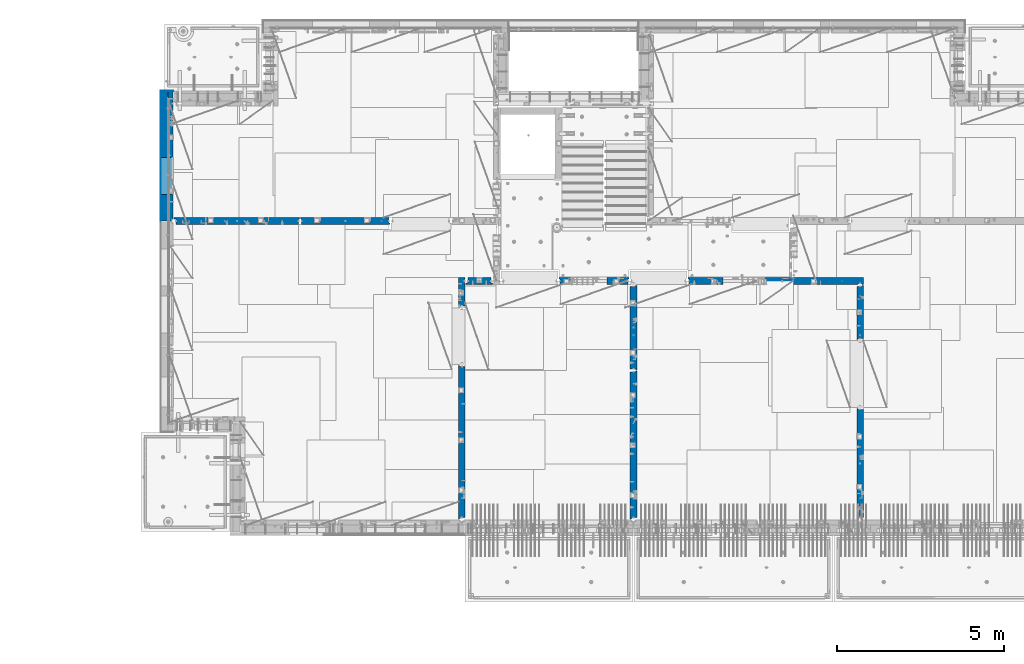
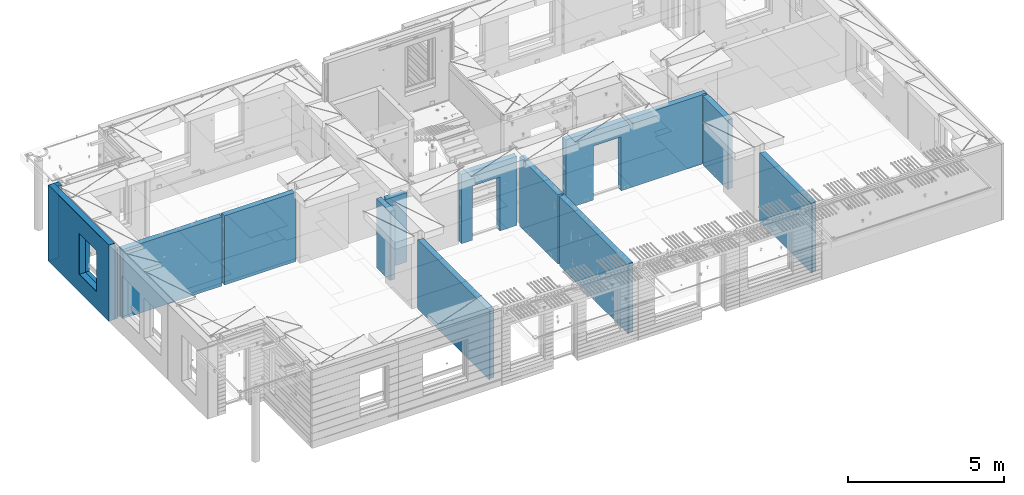
# One storey, part 235 of 350: 16 walls, 12 elements without a shape of their own.
"""IFC2X3 building model written with IfcOpenShell, lengths in millimetres."""

from ifc_helpers import new_model, si_unit, frame, origin_with_axes, place, context, subcontext, project, spatial, faceted_brep, material, type_object, element, aggregate, save


model = new_model("IFC2X3")

# Units and contexts
model_context = context("Model", 3, precision=1e-05, world=origin_with_axes())
body_context = subcontext(model_context, "Body", "Model", "MODEL_VIEW")
ifc_project = project(units=[si_unit("LENGTHUNIT", "METRE", prefix="MILLI"), si_unit("AREAUNIT", "SQUARE_METRE"), si_unit("VOLUMEUNIT", "CUBIC_METRE"), si_unit("MASSUNIT", "GRAM", prefix="KILO"), si_unit("TIMEUNIT", "SECOND"), si_unit("PLANEANGLEUNIT", "RADIAN"), si_unit("SOLIDANGLEUNIT", "STERADIAN"), si_unit("THERMODYNAMICTEMPERATUREUNIT", "DEGREE_CELSIUS"), si_unit("LUMINOUSINTENSITYUNIT", "LUMEN")], contexts=[model_context])

# Site, building, storey
site_placement = place(None, origin_with_axes())
site = spatial("IfcSite", under=ifc_project, at=site_placement, CompositionType="ELEMENT")
building_placement = place(site_placement, origin_with_axes())
building = spatial("IfcBuilding", under=site, at=building_placement, CompositionType="ELEMENT")
storey_placement = place(building_placement, origin_with_axes())
storey = spatial("IfcBuildingStorey", under=building, at=storey_placement, Name="2", CompositionType="ELEMENT", Elevation=0.0)

# Assembly, wall
assembly_1_placement = place(storey_placement, origin_with_axes())
assembly_1 = element("IfcElementAssembly", 1, at=assembly_1_placement, inside=storey, AssemblyPlace="NOTDEFINED", PredefinedType="REINFORCEMENT_UNIT")
ifc_material_1 = material(Name="CONCRETE/C25/30")
wall_type_1 = type_object("IfcWallType", PredefinedType="NOTDEFINED")
wall_1_placement = place(assembly_1_placement, frame((28610.0, 13387.9996249472, 86112.5), z_axis=(0.0, 0.0, 1.0), x_axis=(0.0, 1.0, 0.0)))
wall_1 = element("IfcWall", 2, at=wall_1_placement, type_object=wall_type_1, material=ifc_material_1, context=body_context, shape_type="Brep", body=[
    faceted_brep([(30.9999999999982, 70.0000000000073, 1357.5), (30.9999999999982, 70.0000000000073, -1357.5), (60.9999999999982, 57.0000000000036, -1357.5), (60.9999999999982, 57.0000000000036, 1357.5), (60.9999999999982, -100.0, 1357.5), (60.9999999999982, -100.0, -1357.5), (30.9999999999982, 100.0, -1357.5), (30.9999999999982, 100.0, 1357.5), (1631.00037505278, 100.0, 1357.5), (1631.00037505278, 100.0, -1357.5), (1631.00037505278, -56.9999999999964, 1357.5), (1631.00037505278, -56.9999999999964, -1357.5), (1661.00037505278, -70.0, 1357.5), (1661.00037505278, -70.0, -1357.5), (1661.00037505278, -100.0, 1357.5), (1661.00037505278, -100.0, -1357.5)], [[[0, 1, 2, 3]], [[4, 3, 2, 5]], [[6, 7, 8, 9]], [[10, 11, 9, 8]], [[12, 13, 11, 10]], [[14, 15, 13, 12]], [[15, 14, 4, 5]], [[1, 6, 9, 11, 13, 15, 5, 2]], [[7, 6, 1, 0]], [[14, 12, 10, 8, 7, 0, 3, 4]]]),
])
aggregate(assembly_1, [wall_1])

assembly_2_placement = place(storey_placement, origin_with_axes())
assembly_2 = element("IfcElementAssembly", 3, at=assembly_2_placement, inside=storey, AssemblyPlace="NOTDEFINED", PredefinedType="REINFORCEMENT_UNIT")
wall_2_placement = place(assembly_2_placement, frame((28610.0, 8000.0, 86112.5), z_axis=(0.0, 0.0, 1.0), x_axis=(0.0, 1.0, 0.0)))
wall_2 = element("IfcWall", 4, at=wall_2_placement, type_object=wall_type_1, material=ifc_material_1, context=body_context, shape_type="Brep", body=[
    faceted_brep([(30.0000000000009, 70.0, 1357.5), (30.0, 70.0, -1357.5), (80.0, 57.0, -1357.5), (79.99999955967, 57.0000001052285, 1357.5), (79.9999996695051, -100.0, 1357.5), (80.0, -100.0, -1357.5), (30.0, 100.0, -1357.5), (30.0000000000009, 100.0, 1357.5), (3360.0, 100.0, 1357.5), (3360.0, 100.0, -1357.5), (3360.0, 70.0000000000073, 1357.5), (3360.0, 70.0000000000073, -1357.5), (3330.0, 57.0000000000036, 1357.5), (3330.0, 57.0000000000036, -1357.5), (3330.0, -100.0, 1357.5), (3330.0, -100.0, -1357.5)], [[[0, 1, 2, 3]], [[4, 3, 2, 5]], [[6, 7, 8, 9]], [[9, 8, 10, 11]], [[12, 13, 11, 10]], [[14, 15, 13, 12]], [[15, 14, 4, 5]], [[1, 6, 9, 11, 13, 15, 5, 2]], [[7, 6, 1, 0]], [[14, 12, 10, 8, 7, 0, 3, 4]]]),
])
aggregate(assembly_2, [wall_2])

assembly_3_placement = place(storey_placement, origin_with_axes())
assembly_3 = element("IfcElementAssembly", 5, at=assembly_3_placement, inside=storey, AssemblyPlace="NOTDEFINED", PredefinedType="REINFORCEMENT_UNIT")
wall_3_placement = place(assembly_3_placement, frame((23410.0002919986, 15180.0, 86112.5), z_axis=(0.0, 0.0, 1.0), x_axis=(1.0, 0.0, 0.0)))
wall_3 = element("IfcWall", 6, at=wall_3_placement, type_object=wall_type_1, material=ifc_material_1, context=body_context, shape_type="Brep", body=[
    faceted_brep([(3134.99885559082, 100.0, 762.5), (3147.99885559082, 80.0, 762.5), (3251.99885559082, 80.0, 762.5), (3264.99885559082, 100.0, 762.5), (3147.99885559082, 80.0, 1357.5), (3134.99885559082, 100.0, 1357.5), (3251.99885559082, 80.0, 1357.5), (3264.99885559082, 100.0, 1357.5), (5299.99970800144, -100.0, -1357.5), (5299.99970800144, -100.0, 1357.5), (5264.99970800144, -100.0, 1357.5), (5264.99970800144, -100.0, -1357.5), (5251.99970800144, -70.0, 1357.5), (5251.99970800144, -70.0, -1357.5), (5147.99970800144, -70.0, 1357.5), (5147.99970800144, -70.0, -1357.5), (5134.99970800144, -100.0, 1357.5), (5134.99970800144, -100.0, -1357.5), (59.9988535092562, -100.0, 1357.5), (59.9988535092562, -100.0, -1357.5), (1090.00039464695, -100.0, -1357.5), (1090.00039464695, -100.0, 762.5), (2110.00039464695, -100.0, 762.5), (2110.00039464695, -100.0, -1357.5), (59.9988535092562, 57.0, 1357.5), (59.9988535092562, 57.0, -1357.5), (29.9988535092562, 70.0000000000018, 1357.5), (29.9988535092562, 70.0000000000018, -1357.5), (29.9988535092562, 100.0, 1357.5), (29.9988535092562, 100.0, -1357.5), (1090.00039464695, 100.0, -1357.5), (1090.00039464695, 100.0, 762.5), (2110.00039464695, 100.0, 762.5), (2110.00039464695, 100.0, -1357.5), (5299.99970800144, 100.0, -1357.5), (5299.99970800144, 100.0, 1357.5)], [[[0, 1, 2, 3]], [[4, 1, 0, 5]], [[6, 2, 1, 4]], [[7, 3, 2, 6]], [[8, 9, 10, 11]], [[10, 12, 13, 11]], [[14, 15, 13, 12]], [[16, 17, 15, 14]], [[17, 16, 18, 19, 20, 21, 22, 23]], [[24, 25, 19, 18]], [[26, 27, 25, 24]], [[28, 29, 27, 26]], [[19, 25, 27, 29, 30, 20]], [[31, 21, 20, 30]], [[32, 22, 21, 31]], [[33, 23, 22, 32]], [[34, 8, 11, 13, 15, 17, 23, 33]], [[9, 8, 34, 35]], [[4, 5, 28, 26, 24, 18, 16, 14, 12, 10, 9, 35, 7, 6]], [[35, 34, 33, 32, 31, 30, 29, 28, 5, 0, 3, 7]]]),
])
aggregate(assembly_3, [wall_3])

assembly_4_placement = place(storey_placement, origin_with_axes())
assembly_4 = element("IfcElementAssembly", 7, at=assembly_4_placement, inside=storey, AssemblyPlace="NOTDEFINED", PredefinedType="REINFORCEMENT_UNIT")
wall_4_placement = place(assembly_4_placement, frame((21810.0, 12500.0, 86112.5), z_axis=(0.0, 0.0, 1.0), x_axis=(0.0, 1.0, 0.0)))
wall_4 = element("IfcWall", 8, at=wall_4_placement, type_object=wall_type_1, material=ifc_material_1, context=body_context, shape_type="Brep", body=[
    faceted_brep([(2519.9998239177, -57.0, 1357.5), (2519.9998239177, -57.0, -1357.5), (2519.9998239177, 100.0, -1357.5), (2519.9998239177, 100.0, 1357.5), (2549.9998239177, -70.0, 1357.5), (2549.9998239177, -70.0, -1357.5), (45.0, 100.0, 1357.5), (45.0, 100.0, -1357.5), (45.0, -57.0, -1357.5), (45.0, -57.0, 1357.5), (15.0, -70.0, 1357.5), (15.0, -70.0000000000036, -1357.5), (15.0, -100.0, -1357.5), (15.0, -100.0, 1357.5), (2549.9998239177, -100.0, -1357.5), (2549.9998239177, -100.0, 1357.5)], [[[0, 1, 2, 3]], [[4, 5, 1, 0]], [[6, 7, 8, 9]], [[10, 9, 8, 11]], [[12, 13, 10, 11]], [[13, 12, 14, 15]], [[3, 6, 9, 10, 13, 15, 4, 0]], [[7, 6, 3, 2]], [[14, 12, 11, 8, 7, 2, 1, 5]], [[15, 14, 5, 4]]]),
])
aggregate(assembly_4, [wall_4])

assembly_5_placement = place(storey_placement, origin_with_axes())
assembly_5 = element("IfcElementAssembly", 9, at=assembly_5_placement, inside=storey, AssemblyPlace="NOTDEFINED", PredefinedType="REINFORCEMENT_UNIT")
wall_5_placement = place(assembly_5_placement, frame((21810.0, 8000.0, 86112.5), z_axis=(0.0, 0.0, 1.0), x_axis=(0.0, 1.0, 0.0)))
wall_5 = element("IfcWall", 10, at=wall_5_placement, type_object=wall_type_1, material=ifc_material_1, context=body_context, shape_type="Brep", body=[
    faceted_brep([(30.0000000000009, 70.0, 1357.5), (30.0, 70.0, -1357.5), (80.0, 57.0, -1357.5), (79.99999955967, 57.0000001052285, 1357.5), (79.9999996695051, -100.0, 1357.5), (80.0, -100.0, -1357.5), (30.0, 100.0, -1357.5), (30.0000000000009, 100.0, 1357.5), (4455.0, 100.0, 1357.5), (4455.0, 100.0, -1357.5), (4455.0, -57.0, 1357.5), (4455.0, -57.0, -1357.5), (4485.0, -70.0000000000036, 1357.5), (4485.0, -70.0000000000036, -1357.5), (4485.0, -100.0, 1357.5), (4485.0, -100.0, -1357.5)], [[[0, 1, 2, 3]], [[4, 3, 2, 5]], [[6, 7, 8, 9]], [[10, 11, 9, 8]], [[12, 13, 11, 10]], [[14, 15, 13, 12]], [[15, 14, 4, 5]], [[1, 6, 9, 11, 13, 15, 5, 2]], [[7, 6, 1, 0]], [[14, 12, 10, 8, 7, 0, 3, 4]]]),
])
aggregate(assembly_5, [wall_5])

assembly_6_placement = place(storey_placement, origin_with_axes())
assembly_6 = element("IfcElementAssembly", 11, at=assembly_6_placement, inside=storey, AssemblyPlace="NOTDEFINED", PredefinedType="REINFORCEMENT_UNIT")
wall_6_placement = place(assembly_6_placement, frame((19569.9991455076, 15180.0000000001, 86112.5), z_axis=(0.0, 0.0, 1.0), x_axis=(1.0, 0.0, 0.0)))
wall_6 = element("IfcWall", 12, at=wall_6_placement, type_object=wall_type_1, material=ifc_material_1, context=body_context, shape_type="Brep", body=[
    faceted_brep([(30.0000000001819, 56.9999999999745, 1357.5), (30.0000000001819, 56.9999999999745, -1357.5), (30.0000000001819, -100.0, -1357.5), (30.0000000001819, -100.0, 1357.5), (0.0, 69.9999999999745, 1357.5), (0.0, 69.9999999999745, -1357.5), (1450.00154113788, 100.0, -1357.5), (1450.00154113788, -100.0, -1357.5), (1450.00154113788, -100.0, 762.5), (1450.00154113788, 100.0, 762.5), (430.001541137881, 100.0, 762.5), (430.001541137881, -100.0, 762.5), (430.001541137881, -100.0, -1357.5), (430.001541137881, 100.0, -1357.5), (0.0, 100.0, -1357.5), (0.0, 100.0, 1357.5), (2110.00085449221, 100.0, 1357.5), (2110.00085449221, 100.0, -1357.5), (2110.00085449272, 70.0000000037435, 1357.5), (2110.00085449221, 70.0000000037435, -1357.5), (2080.00085191853, -100.0, -1357.5), (2080.00085558004, 57.0000004585763, -1357.5), (2080.00085558004, 57.0000004585763, 1357.5), (2080.00085191853, -100.0, 1357.5)], [[[0, 1, 2, 3]], [[4, 5, 1, 0]], [[6, 7, 8, 9]], [[10, 11, 12, 13]], [[9, 8, 11, 10]], [[13, 14, 15, 16, 17, 6, 9, 10]], [[17, 16, 18, 19]], [[20, 7, 6, 17, 19, 21]], [[18, 22, 21, 19]], [[23, 20, 21, 22]], [[12, 11, 8, 7, 20, 23, 3, 2]], [[14, 13, 12, 2, 1, 5]], [[15, 14, 5, 4]], [[23, 22, 18, 16, 15, 4, 0, 3]]]),
])
aggregate(assembly_6, [wall_6])

assembly_7_placement = place(storey_placement, origin_with_axes())
assembly_7 = element("IfcElementAssembly", 13, at=assembly_7_placement, inside=storey, AssemblyPlace="NOTDEFINED", PredefinedType="REINFORCEMENT_UNIT")
wall_7_placement = place(assembly_7_placement, frame((16660.0, 8000.0, 86112.5), z_axis=(0.0, 0.0, 1.0), x_axis=(0.0, 1.0, 0.0)))
wall_7 = element("IfcWall", 14, at=wall_7_placement, type_object=wall_type_1, material=ifc_material_1, context=body_context, shape_type="Brep", body=[
    faceted_brep([(30.0000000000009, 70.0, 1357.5), (30.0, 70.0, -1357.5), (80.0, 57.0, -1357.5), (79.99999955967, 57.0000001052285, 1357.5), (79.9999996695051, -100.0, 1357.5), (80.0, -100.0, -1357.5), (30.0, 100.0, -1357.5), (30.0000000000009, 100.0, 1357.5), (4644.99239711402, 100.0, 1357.5), (4644.99239711402, 100.0, -1357.5), (4644.99653549905, 70.0145277302508, 1357.5), (4644.99653549905, 70.0145277302508, -1357.5), (4614.97833252975, 57.001718635147, 1357.5), (4614.97833252975, 57.001718635147, -1357.5), (4615.00000080787, -100.0, 1357.5), (4615.00000080787, -100.0, -1357.5)], [[[0, 1, 2, 3]], [[4, 3, 2, 5]], [[6, 7, 8, 9]], [[9, 8, 10, 11]], [[12, 13, 11, 10]], [[14, 15, 13, 12]], [[15, 14, 4, 5]], [[1, 6, 9, 11, 13, 15, 5, 2]], [[7, 6, 1, 0]], [[14, 12, 10, 8, 7, 0, 3, 4]]]),
])
aggregate(assembly_7, [wall_7])

assembly_8_placement = place(storey_placement, origin_with_axes())
assembly_8 = element("IfcElementAssembly", 15, at=assembly_8_placement, inside=storey, AssemblyPlace="NOTDEFINED", PredefinedType="REINFORCEMENT_UNIT")
wall_8_placement = place(assembly_8_placement, frame((16660.0, 14375.0001284873, 86112.5), z_axis=(0.0, 0.0, 1.0), x_axis=(0.0, 1.0, 0.0)))
wall_8 = element("IfcWall", 16, at=wall_8_placement, type_object=wall_type_1, material=ifc_material_1, context=body_context, shape_type="Brep", body=[
    faceted_brep([(59.9783637637502, 57.008280238686, -607.5), (29.9765698802239, 70.004139724977, -607.5), (29.972430061518, 100.0, -607.5), (84.972430061518, 100.0, -607.5), (84.972430061518, 50.0, -607.5), (59.9793309975266, 50.0, -607.5), (84.972430061518, 50.0, -1357.5), (84.972430061518, 100.0, -1357.5), (59.9793309975285, 50.0, -1357.5), (739.999871512746, -100.0, 1357.5), (752.999871512742, -80.0, 1357.5), (856.999871512742, -80.0, 1357.5), (869.99987151274, -100.0, 1357.5), (904.999871512742, -100.0, 1357.5), (904.999871512742, 100.0, 1357.5), (29.972430061518, 100.0, 1357.5), (29.9765698802239, 70.004139724977, 1357.5), (59.9783637637502, 57.008280238686, 1357.5), (60.0000329474624, -100.0, 1357.5), (739.999871512746, -100.0, -1357.5), (60.0000329474624, -100.0, -1357.5), (752.999871512742, -80.0, -1357.5), (856.999871512742, -80.0, -1357.5), (869.99987151274, -100.0, -1357.5), (904.999871512742, -100.0, -1357.5), (904.999871512742, 100.0, -1357.5)], [[[0, 1, 2, 3, 4, 5]], [[6, 4, 3, 7]], [[8, 5, 4, 6]], [[9, 10, 11, 12, 13, 14, 15, 16, 17, 18]], [[19, 9, 18, 20]], [[9, 19, 21, 10]], [[10, 21, 22, 11]], [[12, 11, 22, 23]], [[24, 13, 12, 23]], [[13, 24, 25, 14]], [[15, 14, 25, 7, 3, 2]], [[16, 15, 2, 1]], [[17, 16, 1, 0]], [[20, 18, 17, 0, 5, 8]], [[25, 24, 23, 22, 21, 19, 20, 8, 6, 7]]]),
])
aggregate(assembly_8, [wall_8])

assembly_9_placement = place(storey_placement, origin_with_axes())
assembly_9 = element("IfcElementAssembly", 17, at=assembly_9_placement, inside=storey, AssemblyPlace="NOTDEFINED", PredefinedType="REINFORCEMENT_UNIT")
wall_9_placement = place(assembly_9_placement, frame((16790.0, 15180.0, 86112.5), z_axis=(0.0, 0.0, 1.0), x_axis=(1.0, 0.0, 0.0)))
wall_9 = element("IfcWall", 18, at=wall_9_placement, type_object=wall_type_1, material=ifc_material_1, context=body_context, shape_type="Brep", body=[
    faceted_brep([(740.0, 100.0, 1357.5), (740.0, -57.0, 1357.5), (740.0, -57.0, -1357.5), (740.0, 100.0, -1357.5), (790.0, -70.0, 1357.5), (790.0, -69.9999999999982, -1357.5), (50.0, 100.0, 1357.5), (50.0, 100.0, -1357.5), (50.0, -48.3299999999999, -1357.5), (50.0, -48.3299999999999, 1357.5), (0.0, -69.996666666666, -1357.5), (0.0, -69.996666666666, 1357.5), (0.0, -100.0, -1357.5), (0.0, -100.0, 1357.5), (790.0, -100.0, -1357.5), (790.0, -100.0, 1357.5)], [[[0, 1, 2, 3]], [[4, 5, 2, 1]], [[6, 7, 8, 9]], [[9, 8, 10, 11]], [[12, 13, 11, 10]], [[13, 12, 14, 15]], [[1, 0, 6, 9, 11, 13, 15, 4]], [[7, 6, 0, 3]], [[14, 12, 10, 8, 7, 3, 2, 5]], [[15, 14, 5, 4]]]),
])
aggregate(assembly_9, [wall_9])

assembly_10_placement = place(storey_placement, origin_with_axes())
assembly_10 = element("IfcElementAssembly", 19, at=assembly_10_placement, inside=storey, AssemblyPlace="NOTDEFINED", PredefinedType="REINFORCEMENT_UNIT")
wall_10_placement = place(assembly_10_placement, frame((11795.0, 16980.0, 86112.5), z_axis=(0.0, 0.0, 1.0), x_axis=(1.0, 0.0, 0.0)))
wall_10 = element("IfcWall", 20, at=wall_10_placement, type_object=wall_type_1, material=ifc_material_1, context=body_context, shape_type="Brep", body=[
    faceted_brep([(2680.0, 100.0, 1357.5), (2680.0, -57.0, 1357.5), (2680.0, -57.0, -1357.50000000001), (2680.0, 100.0, -1357.5), (2705.0, -67.8333333333321, 1357.5), (2705.0, -67.8333333333321, -1357.5), (25.0, 100.0, 1357.5), (25.0, 100.0, -1357.5), (25.0, 70.0000000000036, -1357.5), (25.0, 70.0000000000036, 1357.5), (55.0, 57.0, -1357.5), (55.0, 57.0, 1357.5), (55.0, -100.0, -1357.5), (55.0, -100.0, 1357.5), (2705.0, -100.0, -1357.5), (2705.0, -100.0, 1357.5)], [[[0, 1, 2, 3]], [[4, 5, 2, 1]], [[6, 7, 8, 9]], [[9, 8, 10, 11]], [[11, 10, 12, 13]], [[14, 15, 13, 12]], [[0, 6, 9, 11, 13, 15, 4, 1]], [[7, 6, 0, 3]], [[14, 12, 10, 8, 7, 3, 2, 5]], [[15, 14, 5, 4]]]),
])
aggregate(assembly_10, [wall_10])

assembly_11_placement = place(storey_placement, origin_with_axes())
assembly_11 = element("IfcElementAssembly", 21, at=assembly_11_placement, inside=storey, AssemblyPlace="NOTDEFINED", PredefinedType="REINFORCEMENT_UNIT")
wall_11_placement = place(assembly_11_placement, frame((8000.0, 16980.0, 86112.5), z_axis=(0.0, 0.0, 1.0), x_axis=(1.0, 0.0, 0.0)))
wall_11 = element("IfcWall", 22, at=wall_11_placement, type_object=wall_type_1, material=ifc_material_1, context=body_context, shape_type="Brep", body=[
    faceted_brep([(80.0, 52.0, 1357.5), (80.0, 52.0, -1357.5), (80.0, -100.0, -1357.5), (79.9999996695051, -100.0, 1357.5), (30.0000022791291, 65.0, 1357.5), (30.0000022791291, 65.0, -1357.5), (30.0, 100.0, -1357.5), (30.0000000000009, 100.0, 1357.5), (3790.0, 100.0, 1357.5), (3790.0, 100.0, -1357.5), (3790.0, 70.0000000000036, 1357.5), (3790.0, 70.0000000000036, -1357.5), (3760.0, 57.0, 1357.5), (3760.0, 57.0, -1357.5), (3760.0, -100.0, 1357.5), (3760.0, -100.0, -1357.5)], [[[0, 1, 2, 3]], [[4, 5, 1, 0]], [[6, 7, 8, 9]], [[9, 8, 10, 11]], [[10, 12, 13, 11]], [[14, 15, 13, 12]], [[15, 14, 3, 2]], [[6, 9, 11, 13, 15, 2, 1, 5]], [[7, 6, 5, 4]], [[14, 12, 10, 8, 7, 4, 0, 3]]]),
])
aggregate(assembly_11, [wall_11])

# Assembly, walls
assembly_12_placement = place(storey_placement, origin_with_axes())
assembly_12 = element("IfcElementAssembly", 23, at=assembly_12_placement, inside=storey, AssemblyPlace="NOTDEFINED", PredefinedType="REINFORCEMENT_UNIT")
ifc_material_2 = material()
wall_type_2 = type_object("IfcWallType", PredefinedType="NOTDEFINED")
wall_12_placement = place(assembly_12_placement, frame((7850.0, 20764.9951872276, 86247.5), z_axis=(0.0, 0.0, 1.0), x_axis=(1.0, 0.0, 0.0)))
wall_12 = element("IfcWall", 24, at=wall_12_placement, type_object=wall_type_2, material=ifc_material_2, context=body_context, shape_type="Brep", body=[
    faceted_brep([(0.0, 110.0, -1492.5), (0.0, 110.0, 1492.5), (150.0, 110.0, 1492.5), (150.0, 110.0, -1492.5), (0.0, -110.0, 1492.5), (150.0, -110.0, 1492.5), (0.0, -110.0, -1492.5), (150.0, -110.0, -1492.5)], [[[0, 1, 2, 3]], [[1, 4, 5, 2]], [[4, 6, 7, 5]], [[6, 0, 3, 7]], [[5, 7, 3, 2]], [[6, 4, 1, 0]]]),
])
wall_13_placement = place(assembly_12_placement, frame((7740.0, 16980.0, 86247.5), z_axis=(0.0, 0.0, 1.0), x_axis=(0.0, 1.0, 0.0)))
wall_13 = element("IfcWall", 25, at=wall_13_placement, type_object=wall_type_2, material=ifc_material_2, context=body_context, shape_type="Brep", body=[
    faceted_brep([(5.0, -110.0, 1492.5), (5.0, -110.0, -1492.5), (3894.99518722756, -110.0, -1492.5), (3894.99518722756, -110.0, 1492.5), (795.000410774857, -110.0, -802.5), (795.000410774857, -110.0, 807.5), (1905.00041077486, -110.0, 807.5), (1905.00041077486, -110.0, -802.5), (5.0, 110.0, 1492.5), (3894.99518722756, 110.0, 1492.5), (5.0, 110.0, -1492.5), (3894.99518722756, 110.0, -1492.5), (795.000410774857, 110.0, -802.5), (1905.00041077486, 110.0, -802.5), (1905.00041077486, 110.0, 807.5), (795.000410774857, 110.0, 807.5)], [[[0, 1, 2, 3], [4, 5, 6, 7]], [[8, 0, 3, 9]], [[1, 0, 8, 10]], [[1, 10, 11, 2]], [[3, 2, 11, 9]], [[10, 8, 9, 11], [12, 13, 14, 15]], [[6, 14, 13, 7]], [[5, 15, 14, 6]], [[4, 12, 15, 5]], [[7, 13, 12, 4]]]),
])
wall_type_3 = type_object("IfcWallType", PredefinedType="NOTDEFINED")
wall_14_placement = place(assembly_12_placement, frame((7925.0, 16980.0, 86112.5), z_axis=(0.0, 0.0, 1.0), x_axis=(0.0, 1.0, 0.0)))
wall_14 = element("IfcWall", 26, at=wall_14_placement, type_object=wall_type_3, material=ifc_material_1, context=body_context, shape_type="Brep", body=[
    faceted_brep([(1905.00041077486, -75.0000002638189, -667.5), (1905.00041077486, 75.0, -667.5), (795.000410774857, 75.0, -667.5), (795.000410774857, -75.0000006142109, -667.5), (795.000410774857, 75.0, 942.5), (795.000410774857, -75.0000013255412, 942.5), (1905.00041077486, 75.0, 942.5), (1905.00041077486, -75.0000009751493, 942.5), (3674.99518722756, -75.0, -1357.5), (3674.99518722756, -75.0, 1357.5), (3564.99519001209, -75.0000022791282, 1357.5), (3564.99519001209, -75.0, -1357.5), (3674.99518722756, 75.0, 1357.5), (5.0, 75.0, 1357.5), (5.0, -15.0000022791291, 1357.5), (65.0, -75.0, 1357.5), (3484.99518722756, -75.0000001199542, 1357.5), (3497.99518763813, -54.9999993903657, 1357.5), (3551.99518754267, -54.9999994175314, 1357.5), (5.0, 75.0, -1357.5), (5.0, -15.0000022791291, -1357.5), (65.0, -75.0, -1357.5), (3484.99518722756, -75.0, -1357.5), (3497.99518763813, -54.9999993903657, -1357.5), (3551.99518754267, -54.9999994175314, -1357.5), (3674.99518722756, 75.0, -1357.5)], [[[0, 1, 2, 3]], [[3, 2, 4, 5]], [[5, 4, 6, 7]], [[7, 6, 1, 0]], [[8, 9, 10, 11]], [[9, 12, 13, 14, 15, 16, 17, 18, 10]], [[13, 19, 20, 14]], [[15, 14, 20, 21]], [[15, 21, 22, 16], [3, 5, 7, 0]], [[16, 22, 23, 17]], [[17, 23, 24, 18]], [[10, 18, 24, 11]], [[23, 22, 21, 20, 19, 25, 8, 11, 24]], [[9, 8, 25, 12]], [[19, 13, 12, 25], [2, 1, 6, 4]]]),
])
ifc_material_3 = material(Name="CONCRETE/C30/37")
wall_type_4 = type_object("IfcWallType", PredefinedType="NOTDEFINED")
wall_15_placement = place(assembly_12_placement, frame((7630.0, 20879.9952125549, 86247.5), z_axis=(0.0, 0.0, 1.0), x_axis=(1.0, 0.0, 0.0)))
wall_15 = element("IfcWall", 27, at=wall_15_placement, type_object=wall_type_4, material=ifc_material_3, context=body_context, shape_type="Brep", body=[
    faceted_brep([(0.0, 5.0, -1492.5), (0.0, 5.0, 1492.5), (370.0, 5.0, 1492.5), (370.0, 5.0, -1492.5), (0.0, -5.0, 1492.5), (370.0, -5.0, 1492.5), (0.0, -5.0, -1492.5), (370.0, -5.0, -1492.5)], [[[0, 1, 2, 3]], [[1, 4, 5, 2]], [[4, 6, 7, 5]], [[6, 0, 3, 7]], [[5, 7, 3, 2]], [[6, 4, 1, 0]]]),
])
wall_16_placement = place(assembly_12_placement, frame((7625.0, 16980.0, 86247.5), z_axis=(0.0, 0.0, 1.0), x_axis=(0.0, 1.0, 0.0)))
wall_16 = element("IfcWall", 28, at=wall_16_placement, type_object=wall_type_4, material=ifc_material_3, context=body_context, shape_type="Brep", body=[
    faceted_brep([(5.0, -5.0, 1492.5), (5.0, -5.0, -1492.5), (3904.99518722756, -5.0, -1492.5), (3904.99518722756, -5.0, 1492.5), (795.000410774981, -5.0, -802.5), (795.000410774981, -5.0, 807.5), (1905.00041077498, -5.0, 807.5), (1905.00041077498, -5.0, -802.5), (5.0, 5.0, 1492.5), (3904.99518722756, 5.0, 1492.5), (5.0, 5.0, -1492.5), (3904.99518722756, 5.0, -1492.5), (795.000410774981, 5.0, -802.5), (1905.00041077498, 5.0, -802.5), (1905.00041077498, 5.0, 807.5), (795.000410774981, 5.0, 807.5)], [[[0, 1, 2, 3], [4, 5, 6, 7]], [[8, 0, 3, 9]], [[1, 0, 8, 10]], [[1, 10, 11, 2]], [[3, 2, 11, 9]], [[10, 8, 9, 11], [12, 13, 14, 15]], [[6, 14, 13, 7]], [[5, 15, 14, 6]], [[4, 12, 15, 5]], [[7, 13, 12, 4]]]),
])
aggregate(assembly_12, [wall_12, wall_15, wall_13, wall_16, wall_14])

save(model, "model.ifc")
